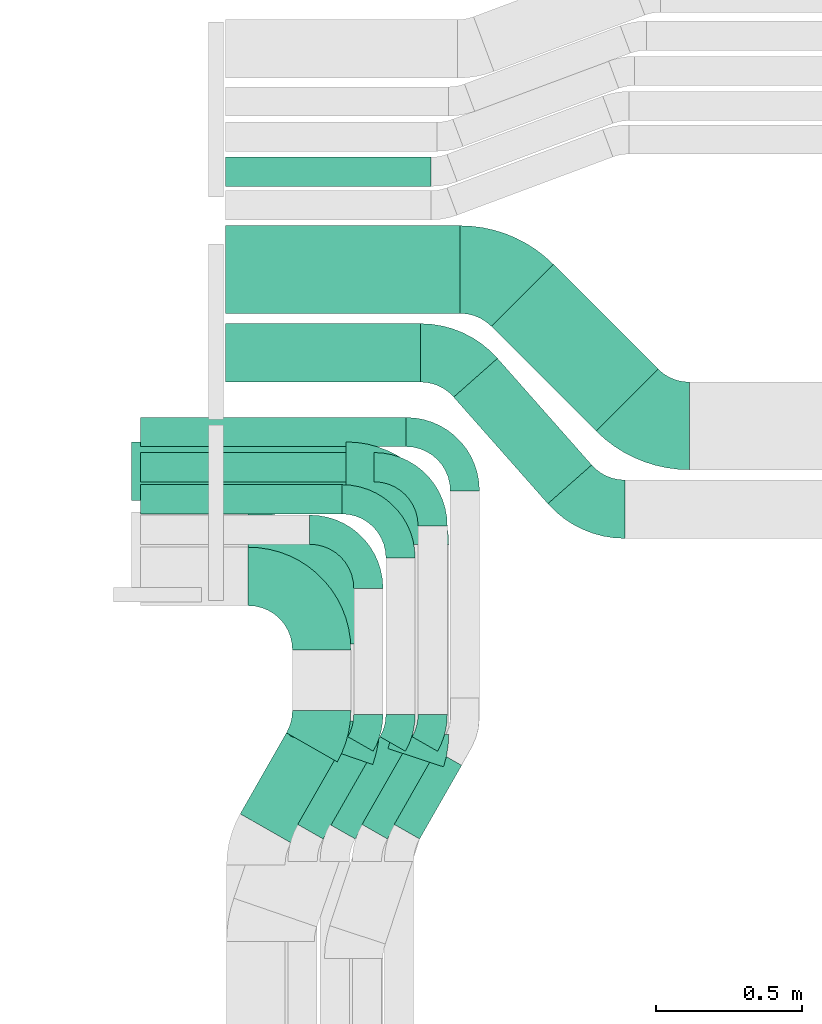
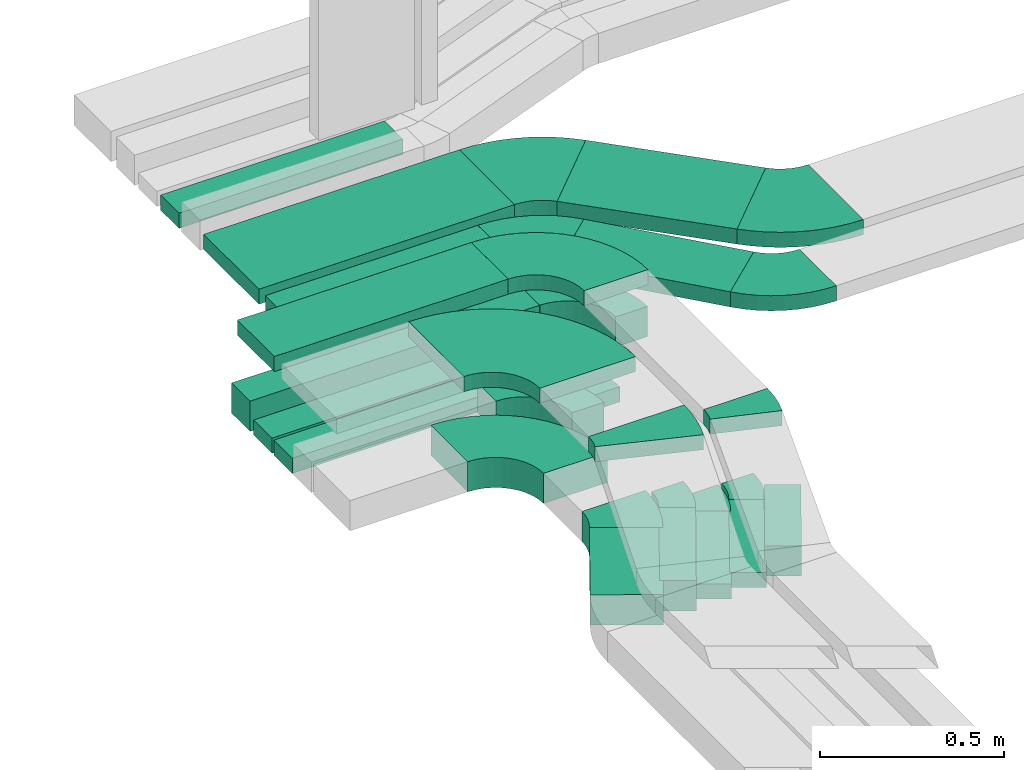
# One storey, part 6 of 28: 17 flow fittings, 14 flow segments.
"""IFC2X3 building model written with IfcOpenShell, lengths in millimetres."""

from ifc_helpers import new_model, entity, si_unit, converted_unit, derived_unit, direction, frame, frame_2d, origin, origin_2d_with_axis, place, context, subcontext, project, spatial, polyline, circle_curve, parameter, trimmed, segment, composite_curve, rectangle, outline, extrude, source, transform, mapped, material, type_object, type_shapes, element, save


model = new_model("IFC2X3")

# Units and contexts
model_context = context("Model", 3, precision=0.01, world=origin(), true_north=direction((6.12303176911189e-17, 1.0)))
body_context = subcontext(model_context, "Body", "Model", "MODEL_VIEW")
ifc_project = project(units=[si_unit("LENGTHUNIT", "METRE", prefix="MILLI"), si_unit("AREAUNIT", "SQUARE_METRE"), si_unit("VOLUMEUNIT", "CUBIC_METRE"), converted_unit("PLANEANGLEUNIT", "DEGREE", entity("IfcRatioMeasure", 0.0174532925199433), si_unit("PLANEANGLEUNIT", "RADIAN"), dimensions=[0, 0, 0, 0, 0, 0, 0]), si_unit("MASSUNIT", "GRAM", prefix="KILO"), derived_unit("MASSDENSITYUNIT", [(si_unit("MASSUNIT", "GRAM", prefix="KILO"), 1), (si_unit("LENGTHUNIT", "METRE"), -3)]), derived_unit("MOMENTOFINERTIAUNIT", [(si_unit("LENGTHUNIT", "METRE"), 4)]), si_unit("TIMEUNIT", "SECOND"), si_unit("FREQUENCYUNIT", "HERTZ"), si_unit("THERMODYNAMICTEMPERATUREUNIT", "DEGREE_CELSIUS"), derived_unit("THERMALTRANSMITTANCEUNIT", [(si_unit("MASSUNIT", "GRAM", prefix="KILO"), 1), (si_unit("THERMODYNAMICTEMPERATUREUNIT", "KELVIN"), -1), (si_unit("TIMEUNIT", "SECOND"), -3)]), derived_unit("VOLUMETRICFLOWRATEUNIT", [(si_unit("LENGTHUNIT", "METRE"), 3), (si_unit("TIMEUNIT", "SECOND"), -1)]), derived_unit("MASSFLOWRATEUNIT", [(si_unit("MASSUNIT", "GRAM", prefix="KILO"), 1), (si_unit("TIMEUNIT", "SECOND"), -1)]), derived_unit("ROTATIONALFREQUENCYUNIT", [(si_unit("TIMEUNIT", "SECOND"), -1)]), si_unit("ELECTRICCURRENTUNIT", "AMPERE"), si_unit("ELECTRICVOLTAGEUNIT", "VOLT"), si_unit("POWERUNIT", "WATT"), si_unit("FORCEUNIT", "NEWTON", prefix="KILO"), si_unit("ILLUMINANCEUNIT", "LUX"), si_unit("LUMINOUSFLUXUNIT", "LUMEN"), si_unit("LUMINOUSINTENSITYUNIT", "CANDELA"), derived_unit("USERDEFINED", [(si_unit("MASSUNIT", "GRAM", prefix="KILO"), -1), (si_unit("LENGTHUNIT", "METRE"), -2), (si_unit("TIMEUNIT", "SECOND"), 3), (si_unit("LUMINOUSFLUXUNIT", "LUMEN"), 1)]), derived_unit("LINEARVELOCITYUNIT", [(si_unit("LENGTHUNIT", "METRE"), 1), (si_unit("TIMEUNIT", "SECOND"), -1)]), si_unit("PRESSUREUNIT", "PASCAL"), derived_unit("USERDEFINED", [(si_unit("LENGTHUNIT", "METRE"), -2), (si_unit("MASSUNIT", "GRAM", prefix="KILO"), 1), (si_unit("TIMEUNIT", "SECOND"), -2)]), derived_unit("LINEARFORCEUNIT", [(si_unit("MASSUNIT", "GRAM", prefix="KILO"), 1), (si_unit("LENGTHUNIT", "METRE"), 1), (si_unit("TIMEUNIT", "SECOND"), -2), (si_unit("LENGTHUNIT", "METRE"), -1)]), derived_unit("PLANARFORCEUNIT", [(si_unit("MASSUNIT", "GRAM", prefix="KILO"), 1), (si_unit("LENGTHUNIT", "METRE"), 1), (si_unit("TIMEUNIT", "SECOND"), -2), (si_unit("LENGTHUNIT", "METRE"), -2)])], contexts=[model_context])

# Site, building, storey
site_placement = place(None, origin())
site = spatial("IfcSite", under=ifc_project, at=site_placement, CompositionType="ELEMENT")
building_placement = place(site_placement, origin())
building = spatial("IfcBuilding", under=site, at=building_placement, CompositionType="ELEMENT")
storey_placement = place(building_placement, frame((0.0, 0.0, 15900.0)))
storey = spatial("IfcBuildingStorey", under=building, at=storey_placement, CompositionType="ELEMENT", Elevation=15900.0)

# Flow segments
cable_carrier_segment_type = type_object("IfcCableCarrierSegmentType", PredefinedType="CABLETRAYSEGMENT")
flow_segment_1_placement = place(storey_placement, frame((16530.0, 15404.46, 2638.31)))
element("IfcFlowSegment", 1, at=flow_segment_1_placement, inside=storey, type_object=cable_carrier_segment_type, context=body_context, shape_type="SweptSolid", body=[
    extrude(rectangle(XDim=702.872698196628, YDim=99.9999999999989, at=origin_2d_with_axis()), frame((351.44, 50.0, 0.0), z_axis=(0.0, 0.0, 1.0), x_axis=(-1.0, 0.0, 0.0)), (0.0, 0.0, 1.0), 50.0000000000016),
])
flow_segment_2_placement = place(storey_placement, frame((16580.06, 13158.71, 2607.26)))
element("IfcFlowSegment", 2, at=flow_segment_2_placement, inside=storey, type_object=cable_carrier_segment_type, context=body_context, shape_type="SweptSolid", body=[
    extrude(rectangle(XDim=319.133502209689, YDim=199.999999999999, at=origin_2d_with_axis()), frame((165.96, 188.15, 0.0), z_axis=(0.0, 0.0, 1.0), x_axis=(-0.495874162367818, -0.868394389143559, 0.0)), (0.0, 0.0, 1.0), 99.9999999999989),
])
flow_segment_3_placement = place(storey_placement, frame((17106.9, 13171.98, 2607.26)))
element("IfcFlowSegment", 3, at=flow_segment_3_placement, inside=storey, type_object=cable_carrier_segment_type, context=body_context, shape_type="SweptSolid", body=[
    extrude(rectangle(XDim=289.923583201512, YDim=100.000000000003, at=origin_2d_with_axis()), frame((115.3, 150.68, 0.0), z_axis=(0.0, 0.0, 1.0), x_axis=(-0.495874162367868, -0.868394389143531, 0.0)), (0.0, 0.0, 1.0), 99.9999999999989),
])
flow_segment_4_placement = place(storey_placement, frame((16776.9, 13171.98, 2607.26)))
element("IfcFlowSegment", 4, at=flow_segment_4_placement, inside=storey, type_object=cable_carrier_segment_type, context=body_context, shape_type="SweptSolid", body=[
    extrude(rectangle(XDim=345.673624854465, YDim=100.000000000001, at=origin_2d_with_axis()), frame((129.13, 174.88, 0.0), z_axis=(0.0, 0.0, 1.0), x_axis=(-0.495874162367857, -0.868394389143537, 0.0)), (0.0, 0.0, 1.0), 99.9999999999989),
])
for number, where in (
    (5, (16886.9, 13171.98, 2607.26)),
    (6, (16996.9, 13171.98, 2607.26)),
):
    element("IfcFlowSegment", number, at=place(storey_placement, frame(where)), inside=storey, type_object=cable_carrier_segment_type, context=body_context, shape_type="SweptSolid", body=[
        extrude(rectangle(XDim=345.67362485447, YDim=100.000000000001, at=origin_2d_with_axis()), frame((129.13, 174.88, 0.0), z_axis=(0.0, 0.0, 1.0), x_axis=(-0.495874162367856, -0.868394389143537, 0.0)), (0.0, 0.0, 1.0), 50.0000000000016),
    ])
flow_segment_5_placement = place(storey_placement, frame((16238.54, 14283.92, 2607.26)))
element("IfcFlowSegment", 7, at=flow_segment_5_placement, inside=storey, type_object=cable_carrier_segment_type, context=body_context, shape_type="SweptSolid", body=[
    extrude(rectangle(XDim=689.000000000006, YDim=99.9999999999989, at=origin_2d_with_axis()), frame((344.5, 50.0, 0.0), z_axis=(0.0, 0.0, 1.0), x_axis=(-1.0, 0.0, 0.0)), (0.0, 0.0, 1.0), 50.0000000000016),
])
flow_segment_6_placement = place(storey_placement, frame((16238.54, 14393.92, 2607.26)))
element("IfcFlowSegment", 8, at=flow_segment_6_placement, inside=storey, type_object=cable_carrier_segment_type, context=body_context, shape_type="SweptSolid", body=[
    extrude(rectangle(XDim=799.000000000003, YDim=99.9999999999989, at=origin_2d_with_axis()), frame((399.5, 50.0, 0.0), z_axis=(0.0, 0.0, 1.0), x_axis=(-1.0, 0.0, 0.0)), (0.0, 0.0, 1.0), 50.0000000000016),
])
flow_segment_7_placement = place(storey_placement, frame((16238.54, 14513.92, 2607.26)))
element("IfcFlowSegment", 9, at=flow_segment_7_placement, inside=storey, type_object=cable_carrier_segment_type, context=body_context, shape_type="SweptSolid", body=[
    extrude(rectangle(XDim=908.999999999999, YDim=99.9999999999989, at=origin_2d_with_axis()), frame((454.5, 50.0, 0.0), z_axis=(0.0, 0.0, 1.0), x_axis=(-1.0, 0.0, 0.0)), (0.0, 0.0, 1.0), 99.9999999999989),
])
flow_segment_8_placement = place(storey_placement, frame((16208.54, 14330.17, 2927.26)))
element("IfcFlowSegment", 10, at=flow_segment_8_placement, inside=storey, type_object=cable_carrier_segment_type, context=body_context, shape_type="SweptSolid", body=[
    extrude(rectangle(XDim=733.999999999982, YDim=200.000000000002, at=origin_2d_with_axis()), frame((367.0, 100.0, 0.0), z_axis=(0.0, 0.0, 1.0), x_axis=(-1.0, 0.0, 0.0)), (0.0, 0.0, 1.0), 50.0000000000016),
])
flow_segment_9_placement = place(storey_placement, frame((16530.0, 14735.0, 2650.0)))
element("IfcFlowSegment", 11, at=flow_segment_9_placement, inside=storey, type_object=cable_carrier_segment_type, context=body_context, shape_type="SweptSolid", body=[
    extrude(rectangle(XDim=666.306441925909, YDim=199.999999999998, at=origin_2d_with_axis()), frame((333.15, 100.0, 0.0)), (0.0, 0.0, 1.0), 50.0000000000016),
])
flow_segment_10_placement = place(storey_placement, frame((17310.36, 14318.99, 2650.0)))
element("IfcFlowSegment", 12, at=flow_segment_10_placement, inside=storey, type_object=cable_carrier_segment_type, context=body_context, shape_type="SweptSolid", body=[
    extrude(rectangle(XDim=486.584397365072, YDim=200.000000000002, at=origin_2d_with_axis()), frame((236.05, 248.52, 0.0), z_axis=(0.0, 0.0, 1.0), x_axis=(-0.662237622743354, 0.749293888286319, 0.0)), (0.0, 0.0, 1.0), 50.0000000000016),
])
flow_segment_11_placement = place(storey_placement, frame((17439.53, 14567.53, 2650.0)))
element("IfcFlowSegment", 13, at=flow_segment_11_placement, inside=storey, type_object=cable_carrier_segment_type, context=body_context, shape_type="SweptSolid", body=[
    extrude(rectangle(XDim=506.040043959347, YDim=299.999999999999, at=origin_2d_with_axis()), frame((284.98, 284.98, 0.0), z_axis=(0.0, 0.0, 1.0), x_axis=(-0.70710678118652, 0.707106781186575, 0.0)), (0.0, 0.0, 1.0), 50.0000000000016),
])
flow_segment_12_placement = place(storey_placement, frame((16530.0, 14970.0, 2650.0)))
element("IfcFlowSegment", 14, at=flow_segment_12_placement, inside=storey, type_object=cable_carrier_segment_type, context=body_context, shape_type="SweptSolid", body=[
    extrude(rectangle(XDim=801.752540136818, YDim=300.000000000001, at=origin_2d_with_axis()), frame((400.88, 150.0, 0.0)), (0.0, 0.0, 1.0), 50.0000000000016),
])

# Flow fittings
ifc_material = material()
cable_carrier_fitting_type_1 = type_object("IfcCableCarrierFittingType", Name="470_DKC_S5_Variable Angle Elbow 0-45:-", PredefinedType="NOTDEFINED", material=ifc_material)
shared_shape_1 = source(origin(), body_context, "Body", "SweptSolid", [
    extrude(outline(composite_curve([segment(polyline([(-150.75, -300.25), (-149.75, -300.25)]), True, "CONTINUOUS"), segment(trimmed(circle_curve(frame_2d((-149.75, 149.75), x_axis=(0.0, -1.0)), 450.0), [parameter(0.0)], [parameter(90.0000000000001)], True, "PARAMETER"), True, "CONTINUOUS"), segment(polyline([(300.25, 149.75), (300.25, 150.75)]), True, "CONTINUOUS"), segment(polyline([(300.25, 150.75), (0.25, 150.75)]), True, "CONTINUOUS"), segment(polyline([(0.25, 150.75), (0.25, 149.75)]), True, "CONTINUOUS"), segment(trimmed(circle_curve(frame_2d((-149.75, 149.75), x_axis=(0.0, -1.0)), 150.0), [parameter(0.0)], [parameter(90.0000000000001)], True, "PARAMETER"), False, "CONTINUOUS"), segment(polyline([(-149.75, -0.25), (-150.75, -0.25)]), True, "CONTINUOUS"), segment(polyline([(-150.75, -0.25), (-150.75, -300.25)]), True, "CONTINUOUS")], self_intersect=False)), frame((-150.25, 150.25, -25.0)), (0.0, 0.0, 1.0), 49.9999999999974),
])
type_shapes(cable_carrier_fitting_type_1, [shared_shape_1])
flow_fitting_1_placement = place(storey_placement, frame((16908.54, 14140.53, 2952.26), z_axis=(0.0, 0.0, 1.0), x_axis=(0.0, 1.0, 0.0)))
element("IfcFlowFitting", 15, at=flow_fitting_1_placement, inside=storey, type_object=cable_carrier_fitting_type_1, material=ifc_material, Name="470_DKC_S5_Variable Angle Elbow 0-45:-", ObjectType="470_DKC_S5_Variable Angle Elbow 0-45:-", context=body_context, shape_type="MappedRepresentation", body=[
    mapped(shared_shape_1, transform((0.0, 0.0, 0.0), scale=1.0)),
])
cable_carrier_fitting_type_2 = type_object("IfcCableCarrierFittingType", Name="470_DKC_S5_Variable Angle Elbow 0-45:-", PredefinedType="NOTDEFINED", material=ifc_material)
shared_shape_2 = source(origin(), body_context, "Body", "SweptSolid", [
    extrude(outline(composite_curve([segment(polyline([(-125.75, -225.25), (-124.75, -225.25)]), True, "CONTINUOUS"), segment(trimmed(circle_curve(frame_2d((-124.75, 124.75), x_axis=(0.0, -1.0)), 350.0), [parameter(0.0)], [parameter(90.0000000000001)], True, "PARAMETER"), True, "CONTINUOUS"), segment(polyline([(225.25, 124.75), (225.25, 125.75)]), True, "CONTINUOUS"), segment(polyline([(225.25, 125.75), (25.25, 125.75)]), True, "CONTINUOUS"), segment(polyline([(25.25, 125.75), (25.25, 124.75)]), True, "CONTINUOUS"), segment(trimmed(circle_curve(frame_2d((-124.75, 124.75), x_axis=(0.0, -1.0)), 150.0), [parameter(0.0)], [parameter(90.0000000000001)], True, "PARAMETER"), False, "CONTINUOUS"), segment(polyline([(-124.75, -25.25), (-125.75, -25.25)]), True, "CONTINUOUS"), segment(polyline([(-125.75, -25.25), (-125.75, -225.25)]), True, "CONTINUOUS")], self_intersect=False)), frame((-125.25, 125.25, -50.0)), (0.0, 0.0, 1.0), 100.0),
])
type_shapes(cable_carrier_fitting_type_2, [shared_shape_2])
flow_fitting_2_placement = place(storey_placement, frame((16858.54, 14070.0, 2657.26), z_axis=(0.0, 0.0, 1.0), x_axis=(0.0, 1.0, 0.0)))
element("IfcFlowFitting", 16, at=flow_fitting_2_placement, inside=storey, type_object=cable_carrier_fitting_type_2, material=ifc_material, Name="470_DKC_S5_Variable Angle Elbow 0-45:-", ObjectType="470_DKC_S5_Variable Angle Elbow 0-45:-", context=body_context, shape_type="MappedRepresentation", body=[
    mapped(shared_shape_2, transform((0.0, 0.0, 0.0), scale=1.0)),
])
cable_carrier_fitting_type_3 = type_object("IfcCableCarrierFittingType", Name="470_DKC_S5_Variable Angle Elbow 0-45:-", PredefinedType="NOTDEFINED", material=ifc_material)
shared_shape_3 = source(origin(), body_context, "Body", "SweptSolid", [
    extrude(outline(composite_curve([segment(polyline([(-100.75, -150.25), (-99.75, -150.25)]), True, "CONTINUOUS"), segment(trimmed(circle_curve(frame_2d((-99.75, 99.75), x_axis=(0.0, -1.0)), 250.0), [parameter(0.0)], [parameter(90.0000000000001)], True, "PARAMETER"), True, "CONTINUOUS"), segment(polyline([(150.25, 99.75), (150.25, 100.75)]), True, "CONTINUOUS"), segment(polyline([(150.25, 100.75), (50.25, 100.75)]), True, "CONTINUOUS"), segment(polyline([(50.25, 100.75), (50.25, 99.75)]), True, "CONTINUOUS"), segment(trimmed(circle_curve(frame_2d((-99.75, 99.75), x_axis=(0.0, -1.0)), 150.0), [parameter(0.0)], [parameter(90.0000000000001)], True, "PARAMETER"), False, "CONTINUOUS"), segment(polyline([(-99.75, -50.25), (-100.75, -50.25)]), True, "CONTINUOUS"), segment(polyline([(-100.75, -50.25), (-100.75, -150.25)]), True, "CONTINUOUS")], self_intersect=False)), frame((-100.25, 100.25, -25.0)), (0.0, 0.0, 1.0), 49.9999999999997),
])
type_shapes(cable_carrier_fitting_type_3, [shared_shape_3])
for number, where, z_axis, x_axis, name in (
    (17, (17128.54, 14333.92, 2632.26), (0.0, 0.0, 1.0), (0.0, 1.0, 0.0), "470_DKC_S5_Variable Angle Elbow 0-45:-"),
    (18, (17238.54, 14443.92, 2632.26), (0.0, 0.0, 1.0), (0.0, 1.0, 0.0), "470_DKC_S5_Variable Angle Elbow 0-45:-"),
):
    element("IfcFlowFitting", number, at=place(storey_placement, frame(where, z_axis=z_axis, x_axis=x_axis)), inside=storey, type_object=cable_carrier_fitting_type_3, material=ifc_material, Name=name, ObjectType="470_DKC_S5_Variable Angle Elbow 0-45:-", context=body_context, shape_type="MappedRepresentation", body=[
        mapped(shared_shape_3, transform((0.0, 0.0, 0.0), scale=1.0)),
    ])
cable_carrier_fitting_type_4 = type_object("IfcCableCarrierFittingType", Name="470_DKC_S5_Variable Angle Elbow 0-45:-", PredefinedType="NOTDEFINED", material=ifc_material)
shared_shape_4 = source(origin(), body_context, "Body", "SweptSolid", [
    extrude(outline(composite_curve([segment(polyline([(-100.75, -150.25), (-99.75, -150.25)]), True, "CONTINUOUS"), segment(trimmed(circle_curve(frame_2d((-99.75, 99.75), x_axis=(0.0, -1.0)), 250.0), [parameter(0.0)], [parameter(90.0000000000001)], True, "PARAMETER"), True, "CONTINUOUS"), segment(polyline([(150.25, 99.75), (150.25, 100.75)]), True, "CONTINUOUS"), segment(polyline([(150.25, 100.75), (50.25, 100.75)]), True, "CONTINUOUS"), segment(polyline([(50.25, 100.75), (50.25, 99.75)]), True, "CONTINUOUS"), segment(trimmed(circle_curve(frame_2d((-99.75, 99.75), x_axis=(0.0, -1.0)), 150.0), [parameter(0.0)], [parameter(90.0000000000001)], True, "PARAMETER"), False, "CONTINUOUS"), segment(polyline([(-99.75, -50.25), (-100.75, -50.25)]), True, "CONTINUOUS"), segment(polyline([(-100.75, -50.25), (-100.75, -150.25)]), True, "CONTINUOUS")], self_intersect=False)), frame((-100.25, 100.25, -50.0)), (0.0, 0.0, 1.0), 100.0),
])
type_shapes(cable_carrier_fitting_type_4, [shared_shape_4])
for number, where, z_axis, x_axis, name in (
    (19, (17018.54, 14230.0, 2657.26), (0.0, 0.0, 1.0), (0.0, 1.0, 0.0), "470_DKC_S5_Variable Angle Elbow 0-45:-"),
    (20, (17348.54, 14563.92, 2657.26), (0.0, 0.0, 1.0), (0.0, 1.0, 0.0), "470_DKC_S5_Variable Angle Elbow 0-45:-"),
):
    element("IfcFlowFitting", number, at=place(storey_placement, frame(where, z_axis=z_axis, x_axis=x_axis)), inside=storey, type_object=cable_carrier_fitting_type_4, material=ifc_material, Name=name, ObjectType="470_DKC_S5_Variable Angle Elbow 0-45:-", context=body_context, shape_type="MappedRepresentation", body=[
        mapped(shared_shape_4, transform((0.0, 0.0, 0.0), scale=1.0)),
    ])
cable_carrier_fitting_type_5 = type_object("IfcCableCarrierFittingType", Name="470_DKC_S5_Variable Angle Elbow 0-45:-", PredefinedType="NOTDEFINED", material=ifc_material)
shared_shape_5 = source(origin(), body_context, "Body", "SweptSolid", [
    extrude(outline(composite_curve([segment(polyline([(-125.75, -225.25), (-124.75, -225.25)]), True, "CONTINUOUS"), segment(trimmed(circle_curve(frame_2d((-124.75, 124.75), x_axis=(0.0, -1.0)), 350.0), [parameter(0.0)], [parameter(90.0)], True, "PARAMETER"), True, "CONTINUOUS"), segment(polyline([(225.25, 124.75), (225.25, 125.75)]), True, "CONTINUOUS"), segment(polyline([(225.25, 125.75), (25.25, 125.75)]), True, "CONTINUOUS"), segment(polyline([(25.25, 125.75), (25.25, 124.75)]), True, "CONTINUOUS"), segment(trimmed(circle_curve(frame_2d((-124.75, 124.75), x_axis=(0.0, -1.0)), 150.0), [parameter(0.0)], [parameter(90.0)], True, "PARAMETER"), False, "CONTINUOUS"), segment(polyline([(-124.75, -25.25), (-125.75, -25.25)]), True, "CONTINUOUS"), segment(polyline([(-125.75, -25.25), (-125.75, -225.25)]), True, "CONTINUOUS")], self_intersect=False)), frame((-125.25, 125.25, -25.0)), (0.0, 0.0, 1.0), 50.000000000001),
])
type_shapes(cable_carrier_fitting_type_5, [shared_shape_5])
flow_fitting_3_placement = place(storey_placement, frame((17193.54, 14430.17, 2952.26), z_axis=(0.0, 0.0, 1.0), x_axis=(0.0, 1.0, 0.0)))
element("IfcFlowFitting", 21, at=flow_fitting_3_placement, inside=storey, type_object=cable_carrier_fitting_type_5, material=ifc_material, Name="470_DKC_S5_Variable Angle Elbow 0-45:-", ObjectType="470_DKC_S5_Variable Angle Elbow 0-45:-", context=body_context, shape_type="MappedRepresentation", body=[
    mapped(shared_shape_5, transform((0.0, 0.0, 0.0), scale=1.0)),
])
cable_carrier_fitting_type_6 = type_object("IfcCableCarrierFittingType", Name="470_DKC_S5_Variable Angle Elbow 0-45:-", PredefinedType="NOTDEFINED", material=ifc_material)
shared_shape_6 = source(origin(), body_context, "Body", "SweptSolid", [
    extrude(outline(composite_curve([segment(polyline([(-62.95, -116.57), (-61.95, -116.57)]), True, "CONTINUOUS"), segment(trimmed(circle_curve(frame_2d((-61.95, 233.43), x_axis=(0.0, -1.0)), 350.0), [parameter(0.0)], [parameter(29.7274101248659)], True, "PARAMETER"), True, "CONTINUOUS"), segment(polyline([(111.6, -70.51), (112.47, -70.02)]), True, "CONTINUOUS"), segment(polyline([(112.47, -70.02), (13.3, 103.66)]), True, "CONTINUOUS"), segment(polyline([(13.3, 103.66), (12.43, 103.17)]), True, "CONTINUOUS"), segment(trimmed(circle_curve(frame_2d((-61.95, 233.43), x_axis=(0.0, -1.0)), 150.0), [parameter(0.0)], [parameter(29.7274101248659)], True, "PARAMETER"), False, "CONTINUOUS"), segment(polyline([(-61.95, 83.43), (-62.95, 83.43)]), True, "CONTINUOUS"), segment(polyline([(-62.95, 83.43), (-62.95, -116.57)]), True, "CONTINUOUS")], self_intersect=False)), frame((-4.4, 16.57, -50.0)), (0.0, 0.0, 1.0), 100.0),
])
type_shapes(cable_carrier_fitting_type_6, [shared_shape_6])
flow_fitting_4_placement = place(storey_placement, frame((16858.54, 13543.92, 2657.26), z_axis=(0.0, 0.0, 1.0), x_axis=(0.495874162367799, 0.86839438914357, 0.0)))
element("IfcFlowFitting", 22, at=flow_fitting_4_placement, inside=storey, type_object=cable_carrier_fitting_type_6, material=ifc_material, Name="470_DKC_S5_Variable Angle Elbow 0-45:-", ObjectType="470_DKC_S5_Variable Angle Elbow 0-45:-", context=body_context, shape_type="MappedRepresentation", body=[
    mapped(shared_shape_6, transform((0.0, 0.0, 0.0), scale=1.0)),
])
cable_carrier_fitting_type_7 = type_object("IfcCableCarrierFittingType", Name="470_DKC_S5_Variable Angle Elbow 0-45:-", PredefinedType="NOTDEFINED", material=ifc_material)
shared_shape_7 = source(origin(), body_context, "Body", "SweptSolid", [
    extrude(outline(composite_curve([segment(polyline([(-50.55, -63.28), (-49.55, -63.28)]), True, "CONTINUOUS"), segment(trimmed(circle_curve(frame_2d((-49.55, 186.72), x_axis=(0.0, -1.0)), 250.0), [parameter(0.0)], [parameter(29.7274101248686)], True, "PARAMETER"), True, "CONTINUOUS"), segment(polyline([(74.41, -30.38), (75.28, -29.89)]), True, "CONTINUOUS"), segment(polyline([(75.28, -29.89), (25.7, 56.95)]), True, "CONTINUOUS"), segment(polyline([(25.7, 56.95), (24.83, 56.46)]), True, "CONTINUOUS"), segment(trimmed(circle_curve(frame_2d((-49.55, 186.72), x_axis=(0.0, -1.0)), 150.0), [parameter(0.0)], [parameter(29.7274101248686)], True, "PARAMETER"), False, "CONTINUOUS"), segment(polyline([(-49.55, 36.72), (-50.55, 36.72)]), True, "CONTINUOUS"), segment(polyline([(-50.55, 36.72), (-50.55, -63.28)]), True, "CONTINUOUS")], self_intersect=False)), frame((-3.53, 13.28, -50.0)), (0.0, 0.0, 1.0), 100.0),
])
type_shapes(cable_carrier_fitting_type_7, [shared_shape_7])
flow_fitting_5_placement = place(storey_placement, frame((17018.54, 13543.92, 2657.26), z_axis=(0.0, 0.0, 1.0), x_axis=(0.495874162367838, 0.868394389143548, 0.0)))
element("IfcFlowFitting", 23, at=flow_fitting_5_placement, inside=storey, type_object=cable_carrier_fitting_type_7, material=ifc_material, Name="470_DKC_S5_Variable Angle Elbow 0-45:-", ObjectType="470_DKC_S5_Variable Angle Elbow 0-45:-", context=body_context, shape_type="MappedRepresentation", body=[
    mapped(shared_shape_7, transform((0.0, 0.0, 0.0), scale=1.0)),
])
cable_carrier_fitting_type_8 = type_object("IfcCableCarrierFittingType", Name="470_DKC_S5_Variable Angle Elbow 0-45:-", PredefinedType="NOTDEFINED", material=ifc_material)
shared_shape_8 = source(origin(), body_context, "Body", "SweptSolid", [
    extrude(outline(composite_curve([segment(polyline([(-50.55, -63.28), (-49.55, -63.28)]), True, "CONTINUOUS"), segment(trimmed(circle_curve(frame_2d((-49.55, 186.72), x_axis=(0.0, -1.0)), 250.0), [parameter(0.0)], [parameter(29.7274101248684)], True, "PARAMETER"), True, "CONTINUOUS"), segment(polyline([(74.41, -30.38), (75.28, -29.89)]), True, "CONTINUOUS"), segment(polyline([(75.28, -29.89), (25.7, 56.95)]), True, "CONTINUOUS"), segment(polyline([(25.7, 56.95), (24.83, 56.46)]), True, "CONTINUOUS"), segment(trimmed(circle_curve(frame_2d((-49.55, 186.72), x_axis=(0.0, -1.0)), 150.0), [parameter(0.0)], [parameter(29.7274101248684)], True, "PARAMETER"), False, "CONTINUOUS"), segment(polyline([(-49.55, 36.72), (-50.55, 36.72)]), True, "CONTINUOUS"), segment(polyline([(-50.55, 36.72), (-50.55, -63.28)]), True, "CONTINUOUS")], self_intersect=False)), frame((-3.53, 13.28, -25.0)), (0.0, 0.0, 1.0), 50.0),
])
type_shapes(cable_carrier_fitting_type_8, [shared_shape_8])
for number, where, z_axis, x_axis, name in (
    (24, (17128.54, 13543.92, 2632.26), (0.0, 0.0, 1.0), (0.495874162367837, 0.868394389143548, 0.0), "470_DKC_S5_Variable Angle Elbow 0-45:-"),
    (25, (17238.54, 13543.92, 2632.26), (0.0, 0.0, 1.0), (0.495874162367837, 0.868394389143548, 0.0), "470_DKC_S5_Variable Angle Elbow 0-45:-"),
):
    element("IfcFlowFitting", number, at=place(storey_placement, frame(where, z_axis=z_axis, x_axis=x_axis)), inside=storey, type_object=cable_carrier_fitting_type_8, material=ifc_material, Name=name, ObjectType="470_DKC_S5_Variable Angle Elbow 0-45:-", context=body_context, shape_type="MappedRepresentation", body=[
        mapped(shared_shape_8, transform((0.0, 0.0, 0.0), scale=1.0)),
    ])
cable_carrier_fitting_type_9 = type_object("IfcCableCarrierFittingType", Name="470_DKC_S5_Variable Angle Elbow 0-45:-", PredefinedType="NOTDEFINED", material=ifc_material)
shared_shape_9 = source(origin(), body_context, "Body", "SweptSolid", [
    extrude(outline(composite_curve([segment(polyline([(-49.91, -158.29), (-48.91, -158.29)]), True, "CONTINUOUS"), segment(trimmed(circle_curve(frame_2d((-48.91, 291.71), x_axis=(0.0, -1.0)), 450.0), [parameter(0.0)], [parameter(19.0370536725762)], True, "PARAMETER"), True, "CONTINUOUS"), segment(polyline([(97.87, -133.67), (98.81, -133.35)]), True, "CONTINUOUS"), segment(polyline([(98.81, -133.35), (0.96, 150.24)]), True, "CONTINUOUS"), segment(polyline([(0.96, 150.24), (0.01, 149.92)]), True, "CONTINUOUS"), segment(trimmed(circle_curve(frame_2d((-48.91, 291.71), x_axis=(0.0, -1.0)), 150.0), [parameter(0.0)], [parameter(19.0370536725762)], True, "PARAMETER"), False, "CONTINUOUS"), segment(polyline([(-48.91, 141.71), (-49.91, 141.71)]), True, "CONTINUOUS"), segment(polyline([(-49.91, 141.71), (-49.91, -158.29)]), True, "CONTINUOUS")], self_intersect=False)), frame((-1.39, 8.29, -25.0)), (0.0, 0.0, 1.0), 49.9999999999993),
])
type_shapes(cable_carrier_fitting_type_9, [shared_shape_9])
flow_fitting_6_placement = place(storey_placement, frame((16908.54, 13524.03, 2952.26), z_axis=(0.0, 0.0, 1.0), x_axis=(0.32617956131449, 0.945307830169986, 0.0)))
element("IfcFlowFitting", 26, at=flow_fitting_6_placement, inside=storey, type_object=cable_carrier_fitting_type_9, material=ifc_material, Name="470_DKC_S5_Variable Angle Elbow 0-45:-", ObjectType="470_DKC_S5_Variable Angle Elbow 0-45:-", context=body_context, shape_type="MappedRepresentation", body=[
    mapped(shared_shape_9, transform((0.0, 0.0, 0.0), scale=1.0)),
])
cable_carrier_fitting_type_10 = type_object("IfcCableCarrierFittingType", Name="470_DKC_S5_Variable Angle Elbow 0-45:-", PredefinedType="NOTDEFINED", material=ifc_material)
shared_shape_10 = source(origin(), body_context, "Body", "SweptSolid", [
    extrude(outline(composite_curve([segment(polyline([(-40.05, -106.34), (-39.05, -106.34)]), True, "CONTINUOUS"), segment(trimmed(circle_curve(frame_2d((-39.05, 243.66), x_axis=(0.0, -1.0)), 350.0), [parameter(0.0)], [parameter(18.2110706859138)], True, "PARAMETER"), True, "CONTINUOUS"), segment(polyline([(70.33, -88.81), (71.28, -88.5)]), True, "CONTINUOUS"), segment(polyline([(71.28, -88.5), (8.78, 101.49)]), True, "CONTINUOUS"), segment(polyline([(8.78, 101.49), (7.83, 101.17)]), True, "CONTINUOUS"), segment(trimmed(circle_curve(frame_2d((-39.05, 243.66), x_axis=(0.0, -1.0)), 150.0), [parameter(0.0)], [parameter(18.2110706859138)], True, "PARAMETER"), False, "CONTINUOUS"), segment(polyline([(-39.05, 93.66), (-40.05, 93.66)]), True, "CONTINUOUS"), segment(polyline([(-40.05, 93.66), (-40.05, -106.34)]), True, "CONTINUOUS")], self_intersect=False)), frame((-1.02, 6.34, -25.0)), (0.0, 0.0, 1.0), 50.0000000000005),
])
type_shapes(cable_carrier_fitting_type_10, [shared_shape_10])
flow_fitting_7_placement = place(storey_placement, frame((17193.54, 13489.03, 2952.26), z_axis=(0.0, 0.0, 1.0), x_axis=(0.312518466204232, 0.949911684464063, 0.0)))
element("IfcFlowFitting", 27, at=flow_fitting_7_placement, inside=storey, type_object=cable_carrier_fitting_type_10, material=ifc_material, Name="470_DKC_S5_Variable Angle Elbow 0-45:-", ObjectType="470_DKC_S5_Variable Angle Elbow 0-45:-", context=body_context, shape_type="MappedRepresentation", body=[
    mapped(shared_shape_10, transform((0.0, 0.0, 0.0), scale=1.0)),
])
cable_carrier_fitting_type_11 = type_object("IfcCableCarrierFittingType", Name="470_DKC_S5_Variable Angle Elbow 0-45:-", PredefinedType="NOTDEFINED", material=ifc_material)
shared_shape_11 = source(origin(), body_context, "Body", "SweptSolid", [
    extrude(outline(composite_curve([segment(polyline([(-94.58, -142.41), (-93.58, -142.41)]), True, "CONTINUOUS"), segment(trimmed(circle_curve(frame_2d((-93.58, 207.59), x_axis=(0.0, -1.0)), 350.0), [parameter(0.0)], [parameter(48.5292492852141)], True, "PARAMETER"), True, "CONTINUOUS"), segment(polyline([(168.68, -24.19), (169.34, -23.44)]), True, "CONTINUOUS"), segment(polyline([(169.34, -23.44), (19.48, 109.01)]), True, "CONTINUOUS"), segment(polyline([(19.48, 109.01), (18.82, 108.26)]), True, "CONTINUOUS"), segment(trimmed(circle_curve(frame_2d((-93.58, 207.59), x_axis=(0.0, -1.0)), 150.0), [parameter(0.0)], [parameter(48.5292492852141)], True, "PARAMETER"), False, "CONTINUOUS"), segment(polyline([(-93.58, 57.59), (-94.58, 57.59)]), True, "CONTINUOUS"), segment(polyline([(-94.58, 57.59), (-94.58, -142.41)]), True, "CONTINUOUS")], self_intersect=False)), frame((-19.12, 42.41, -25.0)), (0.0, 0.0, 1.0), 50.0000000000008),
])
type_shapes(cable_carrier_fitting_type_11, [shared_shape_11])
for number, where, z_axis, x_axis, name in (
    (28, (17782.82, 14300.03, 2675.0), (0.0, 0.0, 1.0), (0.662237622743367, -0.749293888286308, 0.0), "470_DKC_S5_Variable Angle Elbow 0-45:-"),
    (29, (17310.0, 14835.0, 2675.0), (0.0, 0.0, 1.0), (-0.662237622743354, 0.749293888286319, 0.0), "470_DKC_S5_Variable Angle Elbow 0-45:-"),
):
    element("IfcFlowFitting", number, at=place(storey_placement, frame(where, z_axis=z_axis, x_axis=x_axis)), inside=storey, type_object=cable_carrier_fitting_type_11, material=ifc_material, Name=name, ObjectType="470_DKC_S5_Variable Angle Elbow 0-45:-", context=body_context, shape_type="MappedRepresentation", body=[
        mapped(shared_shape_11, transform((0.0, 0.0, 0.0), scale=1.0)),
    ])
cable_carrier_fitting_type_12 = type_object("IfcCableCarrierFittingType", Name="470_DKC_S5_Variable Angle Elbow 0-45:-", PredefinedType="NOTDEFINED", material=ifc_material)
shared_shape_12 = source(origin(), body_context, "Body", "SweptSolid", [
    extrude(outline(composite_curve([segment(polyline([(-106.99, -194.11), (-105.99, -194.11)]), True, "CONTINUOUS"), segment(trimmed(circle_curve(frame_2d((-105.99, 255.89), x_axis=(0.0, -1.0)), 450.0), [parameter(0.0)], [parameter(45.0)], True, "PARAMETER"), True, "CONTINUOUS"), segment(polyline([(212.21, -62.31), (212.91, -61.6)]), True, "CONTINUOUS"), segment(polyline([(212.91, -61.6), (0.78, 150.53)]), True, "CONTINUOUS"), segment(polyline([(0.78, 150.53), (0.07, 149.82)]), True, "CONTINUOUS"), segment(trimmed(circle_curve(frame_2d((-105.99, 255.89), x_axis=(0.0, -1.0)), 150.0), [parameter(0.0)], [parameter(45.0)], True, "PARAMETER"), False, "CONTINUOUS"), segment(polyline([(-105.99, 105.89), (-106.99, 105.89)]), True, "CONTINUOUS"), segment(polyline([(-106.99, 105.89), (-106.99, -194.11)]), True, "CONTINUOUS")], self_intersect=False)), frame((-18.27, 44.11, -25.0)), (0.0, 0.0, 1.0), 49.9999999999982),
])
type_shapes(cable_carrier_fitting_type_12, [shared_shape_12])
for number, where, z_axis, x_axis, name in (
    (30, (17991.99, 14585.03, 2675.0), (0.0, 0.0, 1.0), (0.707106781186545, -0.70710678118655, 0.0), "470_DKC_S5_Variable Angle Elbow 0-45:-"),
    (31, (17457.02, 15120.0, 2675.0), (0.0, 0.0, 1.0), (-0.70710678118652, 0.707106781186575, 0.0), "470_DKC_S5_Variable Angle Elbow 0-45:-"),
):
    element("IfcFlowFitting", number, at=place(storey_placement, frame(where, z_axis=z_axis, x_axis=x_axis)), inside=storey, type_object=cable_carrier_fitting_type_12, material=ifc_material, Name=name, ObjectType="470_DKC_S5_Variable Angle Elbow 0-45:-", context=body_context, shape_type="MappedRepresentation", body=[
        mapped(shared_shape_12, transform((0.0, 0.0, 0.0), scale=1.0)),
    ])

save(model, "model.ifc")
